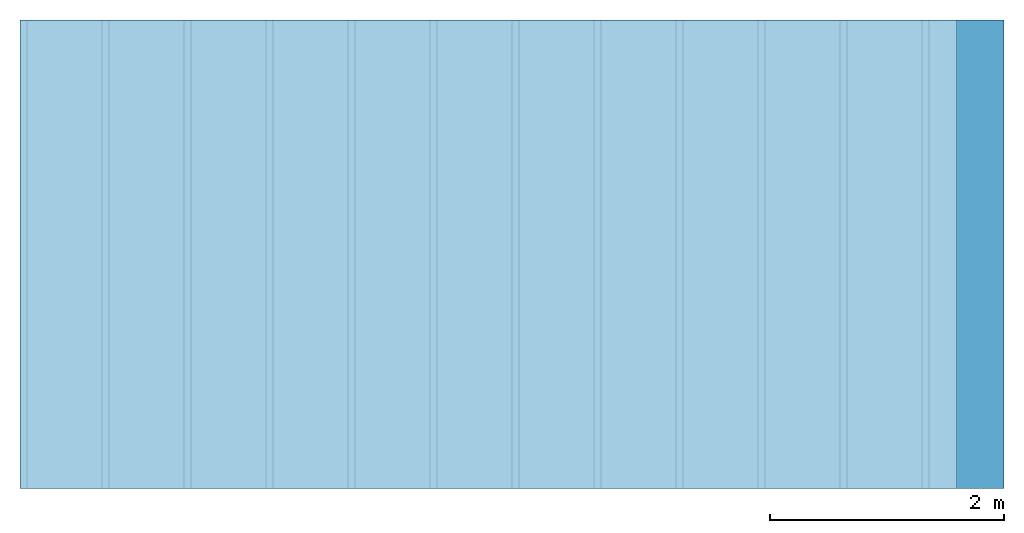
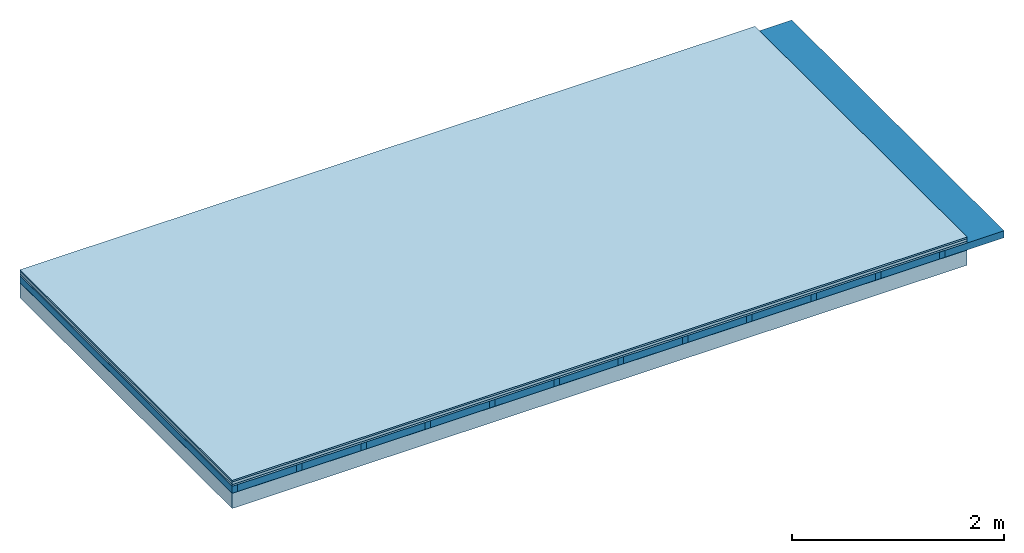
# One storey: 5 plates, 2 members, 1 element without a shape of its own.
"""IFC4 building model written with IfcOpenShell, lengths in metres."""

from ifc_helpers import new_model, si_unit, derived_unit, direction, frame, frame_2d, origin, origin_with_axes, place, context, project, spatial, rectangle, extrude, material, layer, layer_set, type_object, element, aggregate, save


model = new_model("IFC4")

# Units and contexts
plan_context = context("Plan", 3, precision=1e-05, world=origin(), true_north=direction((0.0, 1.0)))
model_context = context("Model", 3, precision=1e-05, world=origin(), true_north=direction((0.0, 1.0)))
ifc_project = project(units=[si_unit("LENGTHUNIT", "METRE"), derived_unit("SOUNDPRESSUREUNIT", [(si_unit("PRESSUREUNIT", "PASCAL", prefix="MICRO"), 0)]), si_unit("ENERGYUNIT", "JOULE", prefix="MEGA"), si_unit("MASSUNIT", "GRAM", prefix="KILO"), derived_unit("THERMALTRANSMITTANCEUNIT", [(si_unit("POWERUNIT", "WATT"), 1), (si_unit("AREAUNIT", "SQUARE_METRE"), -1), (si_unit("THERMODYNAMICTEMPERATUREUNIT", "KELVIN"), -1)]), derived_unit("AREADENSITYUNIT", [(si_unit("MASSUNIT", "GRAM", prefix="KILO"), 1), (si_unit("AREAUNIT", "SQUARE_METRE"), -1)]), derived_unit("USERDEFINED", [(si_unit("ENERGYUNIT", "JOULE", prefix="MEGA"), 1), (si_unit("AREAUNIT", "SQUARE_METRE"), -1)])], contexts=[plan_context, model_context])

# Site, building, storey
site = spatial("IfcSite", under=ifc_project)
building_placement = place(None, origin())
building = spatial("IfcBuilding", under=site, at=building_placement)
storey_placement = place(building_placement, origin())
storey = spatial("IfcBuildingStorey", under=building, at=storey_placement)

# Slab, members, plates
ifc_material_1 = material(Category="03.007")
ifc_layer_1 = layer(ifc_material_1, 0.018, Name="layer")
ifc_material_2 = material(Name="Phone Star TRI", Category="03.013")
ifc_layer_2 = layer(ifc_material_2, 0.03, Name="On-material")
ifc_material_3 = material(Name="Impact sound insulation board TPE", Category="10.008")
ifc_layer_3 = layer(ifc_material_3, 0.02, Name="Impact sound insulation")
ifc_material_4 = material(Name="no composite action")
ifc_layer_4 = layer(ifc_material_4, 0.0, Name="Bond")
ifc_layer_5 = layer(None, 0.08, Name="Supporting structure")
ifc_material_5 = material(Name="protection", Category="09.007")
ifc_layer_6 = layer(ifc_material_5, 0.0005, Name="Lower layer 1")
ifc_material_6 = material(Name="OSB", Category="07.013")
ifc_layer_7 = layer(ifc_material_6, 0.175, Name="Lower 2nd layer")
ifc_layer_set = layer_set([ifc_layer_1, ifc_layer_2, ifc_layer_3, ifc_layer_4, ifc_layer_5, ifc_layer_6, ifc_layer_7])
slab_type = type_object("IfcSlabType", Name="A2716", PredefinedType="NOTDEFINED", material=ifc_layer_set)
slab_placement = place(None, frame((0.0, 0.0, 0.0), z_axis=(0.0, 0.0, -1.0), x_axis=(1.0, 0.0, 0.0)))
slab = element("IfcSlab", 1, at=slab_placement, inside=storey, type_object=slab_type, material=ifc_layer_set, Name="Slab #1")
ifc_material_7 = material()
member_1_placement = place(slab_placement, origin())
member_1 = element("IfcMember", 2, at=member_1_placement, material=ifc_material_7, Name="Supporting structure", context=plan_context, shape_type="SweptSolid", body=[
    extrude(rectangle(XDim=0.06, YDim=0.08, at=frame_2d((0.03, 0.04), x_axis=(1.0, 0.0))), frame((0.0, 4.0, 0.068), z_axis=(0.0, -1.0, 0.0), x_axis=(1.0, 0.0, 0.0)), (0.0, 0.0, 1.0), 4.0),
    extrude(rectangle(XDim=0.06, YDim=0.08, at=frame_2d((0.03, 0.04), x_axis=(1.0, 0.0))), frame((0.7, 4.0, 0.068), z_axis=(0.0, -1.0, 0.0), x_axis=(1.0, 0.0, 0.0)), (0.0, 0.0, 1.0), 4.0),
    extrude(rectangle(XDim=0.06, YDim=0.08, at=frame_2d((0.03, 0.04), x_axis=(1.0, 0.0))), frame((1.4, 4.0, 0.068), z_axis=(0.0, -1.0, 0.0), x_axis=(1.0, 0.0, 0.0)), (0.0, 0.0, 1.0), 4.0),
    extrude(rectangle(XDim=0.06, YDim=0.08, at=frame_2d((0.03, 0.04), x_axis=(1.0, 0.0))), frame((2.1, 4.0, 0.068), z_axis=(0.0, -1.0, 0.0), x_axis=(1.0, 0.0, 0.0)), (0.0, 0.0, 1.0), 4.0),
    extrude(rectangle(XDim=0.06, YDim=0.08, at=frame_2d((0.03, 0.04), x_axis=(1.0, 0.0))), frame((2.8, 4.0, 0.068), z_axis=(0.0, -1.0, 0.0), x_axis=(1.0, 0.0, 0.0)), (0.0, 0.0, 1.0), 4.0),
    extrude(rectangle(XDim=0.06, YDim=0.08, at=frame_2d((0.03, 0.04), x_axis=(1.0, 0.0))), frame((3.5, 4.0, 0.068), z_axis=(0.0, -1.0, 0.0), x_axis=(1.0, 0.0, 0.0)), (0.0, 0.0, 1.0), 4.0),
    extrude(rectangle(XDim=0.06, YDim=0.08, at=frame_2d((0.03, 0.04), x_axis=(1.0, 0.0))), frame((4.2, 4.0, 0.068), z_axis=(0.0, -1.0, 0.0), x_axis=(1.0, 0.0, 0.0)), (0.0, 0.0, 1.0), 4.0),
    extrude(rectangle(XDim=0.06, YDim=0.08, at=frame_2d((0.03, 0.04), x_axis=(1.0, 0.0))), frame((4.9, 4.0, 0.068), z_axis=(0.0, -1.0, 0.0), x_axis=(1.0, 0.0, 0.0)), (0.0, 0.0, 1.0), 4.0),
    extrude(rectangle(XDim=0.06, YDim=0.08, at=frame_2d((0.03, 0.04), x_axis=(1.0, 0.0))), frame((5.6, 4.0, 0.068), z_axis=(0.0, -1.0, 0.0), x_axis=(1.0, 0.0, 0.0)), (0.0, 0.0, 1.0), 4.0),
    extrude(rectangle(XDim=0.06, YDim=0.08, at=frame_2d((0.03, 0.04), x_axis=(1.0, 0.0))), frame((6.3, 4.0, 0.068), z_axis=(0.0, -1.0, 0.0), x_axis=(1.0, 0.0, 0.0)), (0.0, 0.0, 1.0), 4.0),
    extrude(rectangle(XDim=0.06, YDim=0.08, at=frame_2d((0.03, 0.04), x_axis=(1.0, 0.0))), frame((7.0, 4.0, 0.068), z_axis=(0.0, -1.0, 0.0), x_axis=(1.0, 0.0, 0.0)), (0.0, 0.0, 1.0), 4.0),
    extrude(rectangle(XDim=0.06, YDim=0.08, at=frame_2d((0.03, 0.04), x_axis=(1.0, 0.0))), frame((7.7, 4.0, 0.068), z_axis=(0.0, -1.0, 0.0), x_axis=(1.0, 0.0, 0.0)), (0.0, 0.0, 1.0), 4.0),
])
ifc_material_8 = material()
member_2_placement = place(slab_placement, origin())
member_2 = element("IfcMember", 3, at=member_2_placement, material=ifc_material_8, Name="in supporting structure", context=plan_context, shape_type="SweptSolid", body=[
    extrude(rectangle(XDim=0.64, YDim=0.08, at=frame_2d((0.32, 0.04), x_axis=(1.0, 0.0))), frame((0.06, 4.0, 0.068), z_axis=(0.0, -1.0, 0.0), x_axis=(1.0, 0.0, 0.0)), (0.0, 0.0, 1.0), 4.0),
    extrude(rectangle(XDim=0.64, YDim=0.08, at=frame_2d((0.32, 0.04), x_axis=(1.0, 0.0))), frame((0.76, 4.0, 0.068), z_axis=(0.0, -1.0, 0.0), x_axis=(1.0, 0.0, 0.0)), (0.0, 0.0, 1.0), 4.0),
    extrude(rectangle(XDim=0.64, YDim=0.08, at=frame_2d((0.32, 0.04), x_axis=(1.0, 0.0))), frame((1.46, 4.0, 0.068), z_axis=(0.0, -1.0, 0.0), x_axis=(1.0, 0.0, 0.0)), (0.0, 0.0, 1.0), 4.0),
    extrude(rectangle(XDim=0.64, YDim=0.08, at=frame_2d((0.32, 0.04), x_axis=(1.0, 0.0))), frame((2.16, 4.0, 0.068), z_axis=(0.0, -1.0, 0.0), x_axis=(1.0, 0.0, 0.0)), (0.0, 0.0, 1.0), 4.0),
    extrude(rectangle(XDim=0.64, YDim=0.08, at=frame_2d((0.32, 0.04), x_axis=(1.0, 0.0))), frame((2.86, 4.0, 0.068), z_axis=(0.0, -1.0, 0.0), x_axis=(1.0, 0.0, 0.0)), (0.0, 0.0, 1.0), 4.0),
    extrude(rectangle(XDim=0.64, YDim=0.08, at=frame_2d((0.32, 0.04), x_axis=(1.0, 0.0))), frame((3.56, 4.0, 0.068), z_axis=(0.0, -1.0, 0.0), x_axis=(1.0, 0.0, 0.0)), (0.0, 0.0, 1.0), 4.0),
    extrude(rectangle(XDim=0.64, YDim=0.08, at=frame_2d((0.32, 0.04), x_axis=(1.0, 0.0))), frame((4.26, 4.0, 0.068), z_axis=(0.0, -1.0, 0.0), x_axis=(1.0, 0.0, 0.0)), (0.0, 0.0, 1.0), 4.0),
    extrude(rectangle(XDim=0.64, YDim=0.08, at=frame_2d((0.32, 0.04), x_axis=(1.0, 0.0))), frame((4.96, 4.0, 0.068), z_axis=(0.0, -1.0, 0.0), x_axis=(1.0, 0.0, 0.0)), (0.0, 0.0, 1.0), 4.0),
    extrude(rectangle(XDim=0.64, YDim=0.08, at=frame_2d((0.32, 0.04), x_axis=(1.0, 0.0))), frame((5.66, 4.0, 0.068), z_axis=(0.0, -1.0, 0.0), x_axis=(1.0, 0.0, 0.0)), (0.0, 0.0, 1.0), 4.0),
    extrude(rectangle(XDim=0.64, YDim=0.08, at=frame_2d((0.32, 0.04), x_axis=(1.0, 0.0))), frame((6.36, 4.0, 0.068), z_axis=(0.0, -1.0, 0.0), x_axis=(1.0, 0.0, 0.0)), (0.0, 0.0, 1.0), 4.0),
    extrude(rectangle(XDim=0.64, YDim=0.08, at=frame_2d((0.32, 0.04), x_axis=(1.0, 0.0))), frame((7.06, 4.0, 0.068), z_axis=(0.0, -1.0, 0.0), x_axis=(1.0, 0.0, 0.0)), (0.0, 0.0, 1.0), 4.0),
    extrude(rectangle(XDim=0.64, YDim=0.08, at=frame_2d((0.32, 0.04), x_axis=(1.0, 0.0))), frame((7.76, 4.0, 0.068), z_axis=(0.0, -1.0, 0.0), x_axis=(1.0, 0.0, 0.0)), (0.0, 0.0, 1.0), 4.0),
])
plate_1_placement = place(slab_placement, origin())
plate_1 = element("IfcPlate", 4, at=plate_1_placement, material=ifc_material_1, Name="layer", context=plan_context, shape_type="SweptSolid", body=[
    extrude(rectangle(XDim=8.0, YDim=4.0, at=frame_2d((4.0, 2.0), x_axis=(1.0, 0.0))), origin_with_axes(), (0.0, 0.0, 1.0), 0.018),
])
plate_2_placement = place(slab_placement, origin())
plate_2 = element("IfcPlate", 5, at=plate_2_placement, material=ifc_material_2, Name="On-material", context=plan_context, shape_type="SweptSolid", body=[
    extrude(rectangle(XDim=8.0, YDim=4.0, at=frame_2d((4.0, 2.0), x_axis=(1.0, 0.0))), frame((0.0, 0.0, 0.018), z_axis=(0.0, 0.0, 1.0), x_axis=(1.0, 0.0, 0.0)), (0.0, 0.0, 1.0), 0.03),
])
plate_3_placement = place(slab_placement, origin())
plate_3 = element("IfcPlate", 6, at=plate_3_placement, material=ifc_material_3, Name="Impact sound insulation", context=plan_context, shape_type="SweptSolid", body=[
    extrude(rectangle(XDim=8.0, YDim=4.0, at=frame_2d((4.0, 2.0), x_axis=(1.0, 0.0))), frame((0.0, 0.0, 0.048), z_axis=(0.0, 0.0, 1.0), x_axis=(1.0, 0.0, 0.0)), (0.0, 0.0, 1.0), 0.02),
])
plate_4_placement = place(slab_placement, origin())
plate_4 = element("IfcPlate", 7, at=plate_4_placement, material=ifc_material_5, Name="Lower layer 1", context=plan_context, shape_type="SweptSolid", body=[
    extrude(rectangle(XDim=8.0, YDim=4.0, at=frame_2d((4.0, 2.0), x_axis=(1.0, 0.0))), frame((0.0, 0.0, 0.148), z_axis=(0.0, 0.0, 1.0), x_axis=(1.0, 0.0, 0.0)), (0.0, 0.0, 1.0), 0.0005),
])
plate_5_placement = place(slab_placement, origin())
plate_5 = element("IfcPlate", 8, at=plate_5_placement, material=ifc_material_6, Name="Lower 2nd layer", context=plan_context, shape_type="SweptSolid", body=[
    extrude(rectangle(XDim=8.0, YDim=4.0, at=frame_2d((4.0, 2.0), x_axis=(1.0, 0.0))), frame((0.0, 0.0, 0.1485), z_axis=(0.0, 0.0, 1.0), x_axis=(1.0, 0.0, 0.0)), (0.0, 0.0, 1.0), 0.175),
])
aggregate(slab, [plate_1, plate_2, plate_3, member_1, member_2, plate_4, plate_5])

save(model, "model.ifc")
